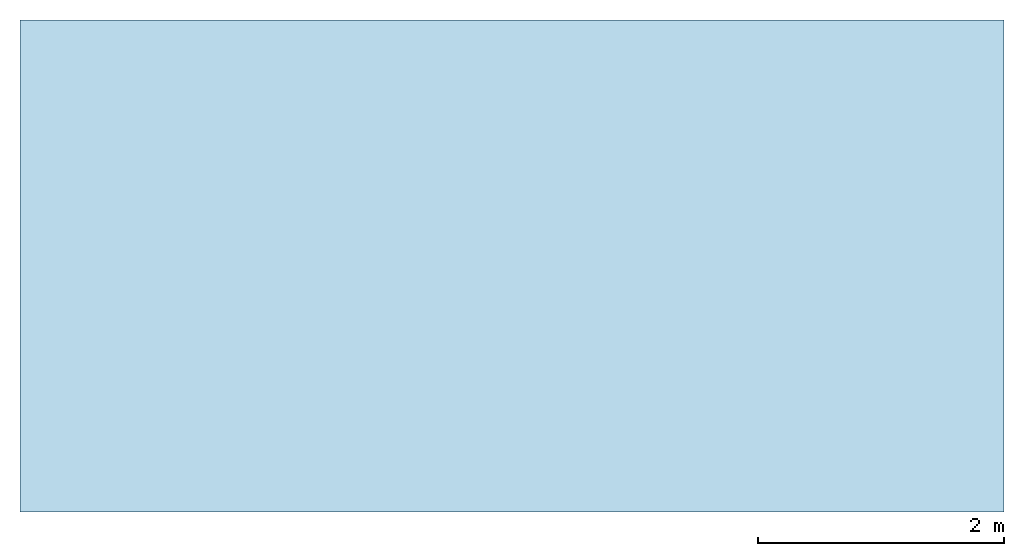
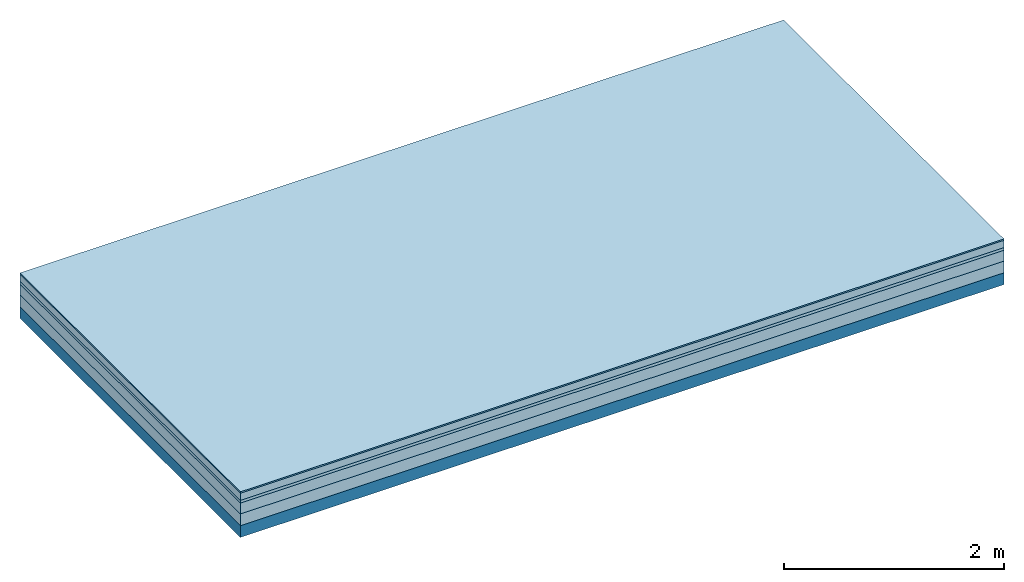
# One storey: 5 plates, 1 member, 1 element without a shape of its own.
"""IFC4 building model written with IfcOpenShell, lengths in metres."""

import ifcopenshell
import ifcopenshell.guid

model = None  # the IFC model being written
_history = None  # IfcOwnerHistory: only IFC2X3 demands one
_inside = {}  # id of a spatial element -> (the spatial element, [elements in it])
_under = {}  # id of a project, library or spatial element -> (it, [spatial elements below it])
_declared = {}  # id of a project -> (the project, [libraries it declares])
_typed = {}  # id of a type object -> (the type object, [elements of that type])
_made_of = {}  # id of a material, layer set ... -> (it, [elements and type objects made of it])


def new_model(schema):
    """Start an empty IFC model of exactly this schema.

    Asked for "IFC4X3", IfcOpenShell would pick the latest addendum, in which some entities
    have other attributes; the version numbers below select the first issue.
    IFC2X3 requires an IfcOwnerHistory on every rooted entity: one is made here for all.
    """
    global model, _history
    if schema == "IFC4X3":
        model = ifcopenshell.file(schema_version=(4, 3, 0, 0))
    else:
        model = ifcopenshell.file(schema=schema)
    _inside.clear()
    _under.clear()
    _declared.clear()
    _typed.clear()
    _made_of.clear()
    _history = None
    if model.schema == "IFC2X3":
        org = make("IfcOrganization", Name="unknown")
        user = make(
            "IfcPersonAndOrganization",
            ThePerson=make("IfcPerson", FamilyName="unknown"),
            TheOrganization=org,
        )
        app = make(
            "IfcApplication",
            ApplicationDeveloper=org,
            Version="unknown",
            ApplicationFullName="unknown",
            ApplicationIdentifier="unknown",
        )
        _history = make(
            "IfcOwnerHistory",
            OwningUser=user,
            OwningApplication=app,
            ChangeAction="ADDED",
            CreationDate=0,
        )
    return model


def make(cls, **values):
    """One entity of the class cls with the attributes given. An attribute that is None is left unset."""
    return model.create_entity(
        cls, **{name: value for name, value in values.items() if value is not None}
    )


def rooted(cls, **values):
    """An entity with a GlobalId (a new one), such as an element, a storey or a relation."""
    return make(cls, GlobalId=ifcopenshell.guid.new(), OwnerHistory=_history, **values)


def si_unit(unit_type, name, prefix=None):
    """IfcSIUnit, for example si_unit("LENGTHUNIT", "METRE", prefix="MILLI")."""
    return make("IfcSIUnit", UnitType=unit_type, Prefix=prefix, Name=name)


def derived_unit(unit_type, elements):
    """IfcDerivedUnit: a product of units, each with its exponent."""
    return make(
        "IfcDerivedUnit",
        Elements=[
            make("IfcDerivedUnitElement", Unit=unit, Exponent=power)
            for unit, power in elements
        ],
        UnitType=unit_type,
    )


def assignment(units):
    """IfcUnitAssignment: the units of a project."""
    return None if units is None else make("IfcUnitAssignment", Units=units)


def point(xyz):
    """IfcCartesianPoint."""
    return None if xyz is None else make("IfcCartesianPoint", Coordinates=xyz)


def direction(xyz):
    """IfcDirection."""
    return None if xyz is None else make("IfcDirection", DirectionRatios=xyz)


def frame(location, z_axis=None, x_axis=None):
    """IfcAxis2Placement3D, a coordinate frame: its origin and axes. An axis left out is left unset."""
    return make(
        "IfcAxis2Placement3D",
        Location=point(location),
        Axis=direction(z_axis),
        RefDirection=direction(x_axis),
    )


def frame_2d(location, x_axis=None):
    """IfcAxis2Placement2D, a coordinate frame in the plane: its origin and x axis."""
    return make(
        "IfcAxis2Placement2D", Location=point(location), RefDirection=direction(x_axis)
    )


def origin():
    """The frame at (0, 0, 0) with its axes left unset."""
    return frame((0.0, 0.0, 0.0))


def origin_with_axes():
    """The frame at (0, 0, 0) with the z axis (0, 0, 1) and the x axis (1, 0, 0) written out."""
    return frame((0.0, 0.0, 0.0), z_axis=(0.0, 0.0, 1.0), x_axis=(1.0, 0.0, 0.0))


def place(relative_to, where):
    """IfcLocalPlacement: puts the frame where relative to a parent placement (None: the world)."""
    return make(
        "IfcLocalPlacement", PlacementRelTo=relative_to, RelativePlacement=where
    )


def context(
    kind, dimensions, precision=None, world=None, true_north=None, identifier=None
):
    """IfcGeometricRepresentationContext, for example the 3D "Model" context."""
    return make(
        "IfcGeometricRepresentationContext",
        ContextIdentifier=identifier,
        ContextType=kind,
        CoordinateSpaceDimension=dimensions,
        Precision=precision,
        WorldCoordinateSystem=world,
        TrueNorth=true_north,
    )


def project(units=None, contexts=None):
    """IfcProject with its units and contexts."""
    return rooted(
        "IfcProject",
        Name="project",
        RepresentationContexts=contexts,
        UnitsInContext=assignment(units),
    )


def spatial(cls, under=None, at=None, **own):
    """A site, building, storey or space (cls), placed at a placement, below another one or the project."""
    s = rooted(cls, ObjectPlacement=at, **own)
    if under is not None:
        _under.setdefault(under.id(), (under, []))[1].append(s)
    return s


def profile(cls, at=None, kind="AREA", **sizes):
    """A parametric profile (cls). Its sizes go by their IFC names, for example OverallWidth=200.0."""
    return make(cls, ProfileType=kind, Position=at, **sizes)


def rectangle(**sizes):
    """IfcRectangleProfileDef."""
    return profile("IfcRectangleProfileDef", **sizes)


def extrude(swept, where, along, depth):
    """IfcExtrudedAreaSolid: the profile swept, set in the frame where, extruded along a direction by depth."""
    return make(
        "IfcExtrudedAreaSolid",
        SweptArea=swept,
        Position=where,
        ExtrudedDirection=direction(along),
        Depth=depth,
    )


def shape(context_of_items, identifier, shape_type, items):
    """IfcShapeRepresentation: the items that make up one representation, for example the "Body"."""
    return make(
        "IfcShapeRepresentation",
        ContextOfItems=context_of_items,
        RepresentationIdentifier=identifier,
        RepresentationType=shape_type,
        Items=items,
    )


def material(Name=None, Category=None):
    """IfcMaterial."""
    return make("IfcMaterial", Name=Name, Category=Category)


def layer(
    of_material, thickness, ventilated=None, Name=None, Category=None, Priority=None
):
    """IfcMaterialLayer: one layer of a wall or slab, of a material (None: an air gap)."""
    return make(
        "IfcMaterialLayer",
        Material=of_material,
        LayerThickness=thickness,
        IsVentilated=ventilated,
        Name=Name,
        Category=Category,
        Priority=Priority,
    )


def layer_set(layers, Name=None):
    """IfcMaterialLayerSet."""
    return make("IfcMaterialLayerSet", MaterialLayers=layers, LayerSetName=Name)


def made_of(thing, what):
    """Note that an element or type object is made of a material, layer set ...; save() writes the relation."""
    if what is not None:
        _made_of.setdefault(what.id(), (what, []))[1].append(thing)
    return thing


def type_object(cls, material=None, **own):
    """A type object (cls), such as IfcWallType, which elements share."""
    return made_of(rooted(cls, **own), material)


def element(
    cls,
    number,
    at=None,
    inside=None,
    cuts=None,
    type_object=None,
    material=None,
    context=None,
    identifier="Body",
    shape_type=None,
    held_by="IfcProductDefinitionShape",
    body=None,
    shapes=None,
    **own,
):
    """One element of the class cls, such as IfcWall. Its Tag is "e" and its number.

    at: its placement. inside: the storey or other place that contains it. cuts: it is an
    opening in that element (IfcRelVoidsElement). A single representation is given by context,
    identifier, shape_type and body (its items); several are given by shapes. held_by: the class
    of the entity that holds the representations. save() writes the other relations.
    """
    e = rooted(cls, Tag="e%d" % number, ObjectPlacement=at, **own)
    if body is not None:
        shapes = [shape(context, identifier, shape_type, body)]
    if shapes is not None:
        e.Representation = make(held_by, Representations=shapes)
    if inside is not None:
        _inside.setdefault(inside.id(), (inside, []))[1].append(e)
    if cuts is not None:
        rooted(
            "IfcRelVoidsElement", RelatingBuildingElement=cuts, RelatedOpeningElement=e
        )
    if type_object is not None:
        _typed.setdefault(type_object.id(), (type_object, []))[1].append(e)
    return made_of(e, material)


def aggregate(whole, parts):
    """IfcRelAggregates: a whole, such as a stair, and the parts it consists of."""
    return rooted("IfcRelAggregates", RelatingObject=whole, RelatedObjects=parts)


def save(model, path):
    """Write the relations noted so far, then the file.

    IfcRelAggregates (storeys below a building ...), IfcRelContainedInSpatialStructure (elements
    in a storey), IfcRelDefinesByType, IfcRelAssociatesMaterial and IfcRelDeclares: one each for
    every whole, place, type object, material and project.
    """
    for whole, parts in _under.values():
        aggregate(whole, parts)
    for where, things in _inside.values():
        rooted(
            "IfcRelContainedInSpatialStructure",
            RelatedElements=things,
            RelatingStructure=where,
        )
    for kind, things in _typed.values():
        rooted("IfcRelDefinesByType", RelatedObjects=things, RelatingType=kind)
    for what, things in _made_of.values():
        rooted("IfcRelAssociatesMaterial", RelatedObjects=things, RelatingMaterial=what)
    for by, libraries in _declared.values():
        rooted("IfcRelDeclares", RelatingContext=by, RelatedDefinitions=libraries)
    model.write(path)


model = new_model("IFC4")

# Units and contexts
plan_context = context("Plan", 3, precision=1e-05, world=origin(), true_north=direction((0.0, 1.0)))
model_context = context("Model", 3, precision=1e-05, world=origin(), true_north=direction((0.0, 1.0)))
ifc_project = project(units=[si_unit("LENGTHUNIT", "METRE"), derived_unit("SOUNDPRESSUREUNIT", [(si_unit("PRESSUREUNIT", "PASCAL", prefix="MICRO"), 0)]), si_unit("ENERGYUNIT", "JOULE", prefix="MEGA"), si_unit("MASSUNIT", "GRAM", prefix="KILO"), derived_unit("THERMALTRANSMITTANCEUNIT", [(si_unit("POWERUNIT", "WATT"), 1), (si_unit("AREAUNIT", "SQUARE_METRE"), -1), (si_unit("THERMODYNAMICTEMPERATUREUNIT", "KELVIN"), -1)]), derived_unit("AREADENSITYUNIT", [(si_unit("MASSUNIT", "GRAM", prefix="KILO"), 1), (si_unit("AREAUNIT", "SQUARE_METRE"), -1)]), derived_unit("USERDEFINED", [(si_unit("ENERGYUNIT", "JOULE", prefix="MEGA"), 1), (si_unit("AREAUNIT", "SQUARE_METRE"), -1)])], contexts=[plan_context, model_context])

# Site, building, storey
site = spatial("IfcSite", under=ifc_project)
building_placement = place(None, origin())
building = spatial("IfcBuilding", under=site, at=building_placement)
storey_placement = place(building_placement, origin())
storey = spatial("IfcBuildingStorey", under=building, at=storey_placement)

# Slab, member, plates
ifc_material_1 = material(Category="11.013")
ifc_layer_1 = layer(ifc_material_1, 0.015, Name="Flooring")
ifc_material_2 = material(Name="Cement screed", Category="04.006")
ifc_layer_2 = layer(ifc_material_2, 0.08, Name="On-material")
ifc_material_3 = material(Name="Wood fiber generic product", Category="10.009")
ifc_layer_3 = layer(ifc_material_3, 0.03, Name="Impact sound insulation")
ifc_material_4 = material(Name="Cement screed with EPS", Category="04.006")
ifc_layer_4 = layer(ifc_material_4, 0.12, Name="on Supporting structure")
ifc_material_5 = material(Category="01.002")
ifc_layer_5 = layer(ifc_material_5, 0.13, Name="Sub-floor")
ifc_material_6 = material(Name="Rigid, of the art")
ifc_layer_6 = layer(ifc_material_6, 0.0, Name="Bond")
ifc_layer_7 = layer(None, 0.13, Name="Supporting structure")
ifc_layer_set = layer_set([ifc_layer_1, ifc_layer_2, ifc_layer_3, ifc_layer_4, ifc_layer_5, ifc_layer_6, ifc_layer_7])
slab_type = type_object("IfcSlabType", Name="A2218", PredefinedType="NOTDEFINED", material=ifc_layer_set)
slab_placement = place(None, frame((0.0, 0.0, 0.0), z_axis=(0.0, 0.0, -1.0), x_axis=(1.0, 0.0, 0.0)))
slab = element("IfcSlab", 1, at=slab_placement, inside=storey, type_object=slab_type, material=ifc_layer_set, Name="Slab #1")
ifc_material_7 = material(Name="Solid timber panel")
member_placement = place(slab_placement, origin())
member = element("IfcMember", 2, at=member_placement, material=ifc_material_7, Name="Supporting structure", context=plan_context, shape_type="SweptSolid", body=[
    extrude(rectangle(XDim=1.0, YDim=0.13, at=frame_2d((0.5, 0.065), x_axis=(1.0, 0.0))), frame((0.0, 4.0, 0.375), z_axis=(0.0, -1.0, 0.0), x_axis=(1.0, 0.0, 0.0)), (0.0, 0.0, 1.0), 4.0),
    extrude(rectangle(XDim=1.0, YDim=0.13, at=frame_2d((0.5, 0.065), x_axis=(1.0, 0.0))), frame((1.0, 4.0, 0.375), z_axis=(0.0, -1.0, 0.0), x_axis=(1.0, 0.0, 0.0)), (0.0, 0.0, 1.0), 4.0),
    extrude(rectangle(XDim=1.0, YDim=0.13, at=frame_2d((0.5, 0.065), x_axis=(1.0, 0.0))), frame((2.0, 4.0, 0.375), z_axis=(0.0, -1.0, 0.0), x_axis=(1.0, 0.0, 0.0)), (0.0, 0.0, 1.0), 4.0),
    extrude(rectangle(XDim=1.0, YDim=0.13, at=frame_2d((0.5, 0.065), x_axis=(1.0, 0.0))), frame((3.0, 4.0, 0.375), z_axis=(0.0, -1.0, 0.0), x_axis=(1.0, 0.0, 0.0)), (0.0, 0.0, 1.0), 4.0),
    extrude(rectangle(XDim=1.0, YDim=0.13, at=frame_2d((0.5, 0.065), x_axis=(1.0, 0.0))), frame((4.0, 4.0, 0.375), z_axis=(0.0, -1.0, 0.0), x_axis=(1.0, 0.0, 0.0)), (0.0, 0.0, 1.0), 4.0),
    extrude(rectangle(XDim=1.0, YDim=0.13, at=frame_2d((0.5, 0.065), x_axis=(1.0, 0.0))), frame((5.0, 4.0, 0.375), z_axis=(0.0, -1.0, 0.0), x_axis=(1.0, 0.0, 0.0)), (0.0, 0.0, 1.0), 4.0),
    extrude(rectangle(XDim=1.0, YDim=0.13, at=frame_2d((0.5, 0.065), x_axis=(1.0, 0.0))), frame((6.0, 4.0, 0.375), z_axis=(0.0, -1.0, 0.0), x_axis=(1.0, 0.0, 0.0)), (0.0, 0.0, 1.0), 4.0),
    extrude(rectangle(XDim=1.0, YDim=0.13, at=frame_2d((0.5, 0.065), x_axis=(1.0, 0.0))), frame((7.0, 4.0, 0.375), z_axis=(0.0, -1.0, 0.0), x_axis=(1.0, 0.0, 0.0)), (0.0, 0.0, 1.0), 4.0),
])
plate_1_placement = place(slab_placement, origin())
plate_1 = element("IfcPlate", 3, at=plate_1_placement, material=ifc_material_1, Name="Flooring", context=plan_context, shape_type="SweptSolid", body=[
    extrude(rectangle(XDim=8.0, YDim=4.0, at=frame_2d((4.0, 2.0), x_axis=(1.0, 0.0))), origin_with_axes(), (0.0, 0.0, 1.0), 0.015),
])
plate_2_placement = place(slab_placement, origin())
plate_2 = element("IfcPlate", 4, at=plate_2_placement, material=ifc_material_2, Name="On-material", context=plan_context, shape_type="SweptSolid", body=[
    extrude(rectangle(XDim=8.0, YDim=4.0, at=frame_2d((4.0, 2.0), x_axis=(1.0, 0.0))), frame((0.0, 0.0, 0.015), z_axis=(0.0, 0.0, 1.0), x_axis=(1.0, 0.0, 0.0)), (0.0, 0.0, 1.0), 0.08),
])
plate_3_placement = place(slab_placement, origin())
plate_3 = element("IfcPlate", 5, at=plate_3_placement, material=ifc_material_3, Name="Impact sound insulation", context=plan_context, shape_type="SweptSolid", body=[
    extrude(rectangle(XDim=8.0, YDim=4.0, at=frame_2d((4.0, 2.0), x_axis=(1.0, 0.0))), frame((0.0, 0.0, 0.095), z_axis=(0.0, 0.0, 1.0), x_axis=(1.0, 0.0, 0.0)), (0.0, 0.0, 1.0), 0.03),
])
plate_4_placement = place(slab_placement, origin())
plate_4 = element("IfcPlate", 6, at=plate_4_placement, material=ifc_material_4, Name="on Supporting structure", context=plan_context, shape_type="SweptSolid", body=[
    extrude(rectangle(XDim=8.0, YDim=4.0, at=frame_2d((4.0, 2.0), x_axis=(1.0, 0.0))), frame((0.0, 0.0, 0.125), z_axis=(0.0, 0.0, 1.0), x_axis=(1.0, 0.0, 0.0)), (0.0, 0.0, 1.0), 0.12),
])
plate_5_placement = place(slab_placement, origin())
plate_5 = element("IfcPlate", 7, at=plate_5_placement, material=ifc_material_5, Name="Sub-floor", context=plan_context, shape_type="SweptSolid", body=[
    extrude(rectangle(XDim=8.0, YDim=4.0, at=frame_2d((4.0, 2.0), x_axis=(1.0, 0.0))), frame((0.0, 0.0, 0.245), z_axis=(0.0, 0.0, 1.0), x_axis=(1.0, 0.0, 0.0)), (0.0, 0.0, 1.0), 0.13),
])
aggregate(slab, [plate_1, plate_2, plate_3, plate_4, plate_5, member])

save(model, "model.ifc")
